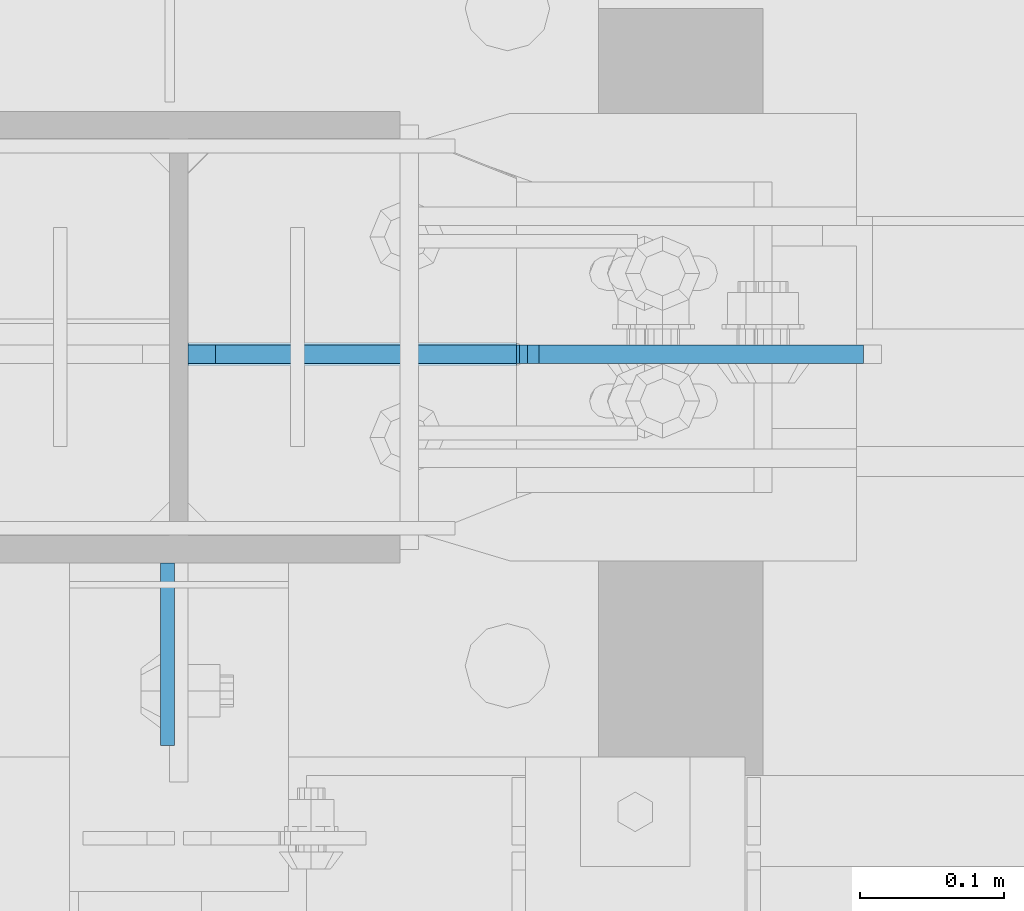
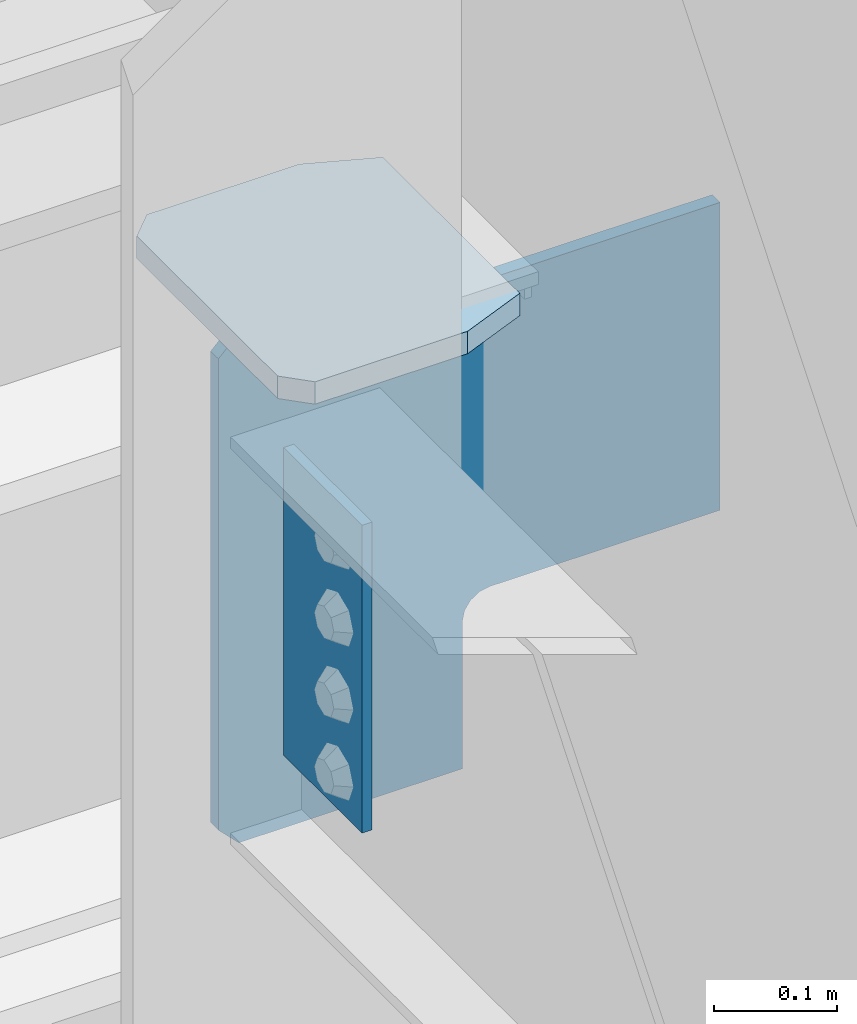
# One storey, part 1107 of 1179: 3 plates, 1 element without a shape of its own.
"""IFC2X3 building model written with IfcOpenShell, lengths in millimetres."""

from ifc_helpers import new_model, si_unit, frame, origin_with_axes, place, context, subcontext, project, spatial, faceted_brep, material, type_object, element, aggregate, save


model = new_model("IFC2X3")

# Units and contexts
model_context = context("Model", 3, precision=1e-05, world=origin_with_axes())
body_context = subcontext(model_context, "Body", "Model", "MODEL_VIEW")
ifc_project = project(units=[si_unit("LENGTHUNIT", "METRE", prefix="MILLI"), si_unit("AREAUNIT", "SQUARE_METRE"), si_unit("VOLUMEUNIT", "CUBIC_METRE"), si_unit("MASSUNIT", "GRAM", prefix="KILO"), si_unit("TIMEUNIT", "SECOND"), si_unit("PLANEANGLEUNIT", "RADIAN"), si_unit("SOLIDANGLEUNIT", "STERADIAN"), si_unit("THERMODYNAMICTEMPERATUREUNIT", "DEGREE_CELSIUS"), si_unit("LUMINOUSINTENSITYUNIT", "LUMEN")], contexts=[model_context])

# Site, building, storey
site_placement = place(None, origin_with_axes())
site = spatial("IfcSite", under=ifc_project, at=site_placement, CompositionType="ELEMENT")
building_placement = place(site_placement, origin_with_axes())
building = spatial("IfcBuilding", under=site, at=building_placement, Name="Undefined", CompositionType="ELEMENT")
storey_placement = place(building_placement, origin_with_axes())
storey = spatial("IfcBuildingStorey", under=building, at=storey_placement, Name="Undefined", CompositionType="ELEMENT", Elevation=0.0)

# Assembly, plates
assembly_placement = place(storey_placement, origin_with_axes())
assembly = element("IfcElementAssembly", 1, at=assembly_placement, inside=storey, Name="COLUMN", AssemblyPlace="NOTDEFINED", PredefinedType="RIGID_FRAME")
ifc_material_1 = material(Name="STEEL/A36")
plate_type_1 = type_object("IfcPlateType", PredefinedType="NOTDEFINED")
plate_1_placement = place(assembly_placement, frame((16451.2625, 41041.6375, 4063.99999886453), z_axis=(0.0, -1.0, 0.0), x_axis=(0.0, 0.0, -1.0)))
plate_1 = element("IfcPlate", 2, at=plate_1_placement, type_object=plate_type_1, material=ifc_material_1, Name="PLATE", context=body_context, shape_type="Brep", body=[
    faceted_brep([(0.0, -4.76249999999709, 0.0), (0.0, -4.76249999999709, 127.0), (0.0, 4.76249999999709, 127.0), (0.0, 4.76249999999709, 0.0), (304.799999999999, -4.76249999999982, 127.0), (304.799999999999, 4.76249999999982, 127.0), (304.799987792969, -4.76250000000073, 0.0), (304.799987792969, 4.76250000000073, 0.0)], [[[0, 1, 2, 3]], [[2, 1, 4, 5]], [[4, 6, 7, 5]], [[6, 0, 3, 7]], [[5, 7, 3, 2]], [[6, 4, 1, 0]]]),
])
ifc_material_2 = material(Name="STEEL/A572-GR.50")
plate_type_2 = type_object("IfcPlateType", PredefinedType="NOTDEFINED")
plate_2_placement = place(assembly_placement, frame((16694.15, 41062.275, 4090.9875), z_axis=(0.0, 1.0, 0.0), x_axis=(-1.0, 0.0, 0.0)))
plate_2 = element("IfcPlate", 3, at=plate_2_placement, type_object=plate_type_2, material=ifc_material_2, Name="PLATE", context=body_context, shape_type="Brep", body=[
    faceted_brep([(63.5, -11.1125000000002, 0.0), (0.0, -11.1125000000002, 25.3999996185303), (0.0, 11.1125000000002, 25.3999996185303), (63.5, 11.1125000000002, 0.0), (0.0, -11.1125000000002, 247.650000381473), (63.5, -11.1125000000002, 273.050000000003), (63.5, 11.1125000000002, 273.050000000003), (0.0, 11.1125000000002, 247.650000381473), (206.374999618529, -11.1125000000002, 273.050000000003), (206.374999618529, 11.1125000000002, 273.050000000003), (228.599999999999, -11.1125000000002, 250.824999618533), (228.599999999999, 11.1125000000002, 250.824999618533), (228.599999999999, -11.1125000000002, 22.2250003814697), (228.599999999999, 11.1125000000002, 22.2250003814697), (206.374999618529, -11.1125000000002, 0.0), (206.374999618529, 11.1125000000002, 0.0)], [[[0, 1, 2, 3]], [[4, 5, 6, 7]], [[5, 8, 9, 6]], [[8, 10, 11, 9]], [[10, 12, 13, 11]], [[12, 14, 15, 13]], [[14, 0, 3, 15]], [[6, 9, 11, 13, 15, 3, 2, 7]], [[1, 4, 7, 2]], [[0, 14, 12, 10, 8, 5, 4, 1]]]),
])
plate_type_3 = type_object("IfcPlateType", PredefinedType="NOTDEFINED")
plate_3_placement = place(assembly_placement, frame((16465.55, 41186.89375, 4079.875), z_axis=(1.0, 0.0, 0.0), x_axis=(0.0, 0.0, -1.0)))
plate_3 = element("IfcPlate", 4, at=plate_3_placement, type_object=plate_type_3, material=ifc_material_2, Name="PLATE", context=body_context, shape_type="Brep", body=[
    faceted_brep([(0.0, -6.35000000000036, 19.0499999999993), (0.0, -6.34999999999854, 228.600000000002), (0.0, 6.34999999999854, 228.600000000002), (0.0, 6.35000000000036, 19.0499999999993), (3.17500038147, -6.34999999999854, 228.600000000002), (3.17500038147, 6.34999999999854, 228.600000000002), (12.895159417561, -6.34999999999854, 230.533459845177), (12.895159417561, 6.34999999999854, 230.533459845177), (21.1355123538683, -6.34999999999854, 236.039487646132), (21.1355123538683, 6.34999999999854, 236.039487646132), (26.6415401548247, -6.34999999999854, 244.27984058244), (26.6415401548247, 6.34999999999854, 244.27984058244), (28.5750000000003, -6.34999999999854, 253.999999618532), (28.5750000000003, 6.34999999999854, 253.999999618532), (28.5750000000003, -6.34999999999854, 469.899999999998), (28.5750000000003, 6.34999999999854, 469.899999999998), (333.375, -6.34999999999854, 469.899999999998), (333.375, 6.34999999999854, 469.899999999998), (333.375, -6.34999999999854, 253.999999618532), (333.375, 6.34999999999854, 253.999999618532), (335.308459845176, -6.34999999999854, 244.27984058244), (335.308459845176, 6.34999999999854, 244.27984058244), (340.814487646132, -6.34999999999854, 236.039487646132), (340.814487646132, 6.34999999999854, 236.039487646132), (349.05484058244, -6.34999999999854, 230.533459845177), (349.05484058244, 6.34999999999854, 230.533459845177), (358.774999618531, -6.34999999999854, 228.600000000002), (358.774999618531, 6.34999999999854, 228.600000000002), (504.825, -6.34999999999854, 228.600000000002), (504.825, 6.34999999999854, 228.600000000002), (504.825, -6.34999999999854, 19.0499992370605), (504.825, 6.34999999999854, 19.0499992370605), (485.77500076294, -6.34999999999854, 0.0), (485.77500076294, 6.34999999999854, 0.0), (19.0500000000002, -6.35000000000036, 0.0), (19.0500000000002, 6.35000000000036, 0.0)], [[[0, 1, 2, 3]], [[1, 4, 5, 2]], [[4, 6, 7, 5]], [[6, 8, 9, 7]], [[8, 10, 11, 9]], [[10, 12, 13, 11]], [[12, 14, 15, 13]], [[14, 16, 17, 15]], [[16, 18, 19, 17]], [[18, 20, 21, 19]], [[20, 22, 23, 21]], [[22, 24, 25, 23]], [[24, 26, 27, 25]], [[26, 28, 29, 27]], [[28, 30, 31, 29]], [[30, 32, 33, 31]], [[32, 34, 35, 33]], [[3, 35, 34, 0]], [[5, 7, 9, 11, 13, 15, 17, 19, 21, 23, 25, 27, 29, 31, 33, 35, 3, 2]], [[34, 32, 30, 28, 26, 24, 22, 20, 18, 16, 14, 12, 10, 8, 6, 4, 1, 0]]]),
])
aggregate(assembly, [plate_2, plate_3, plate_1])

save(model, "model.ifc")
